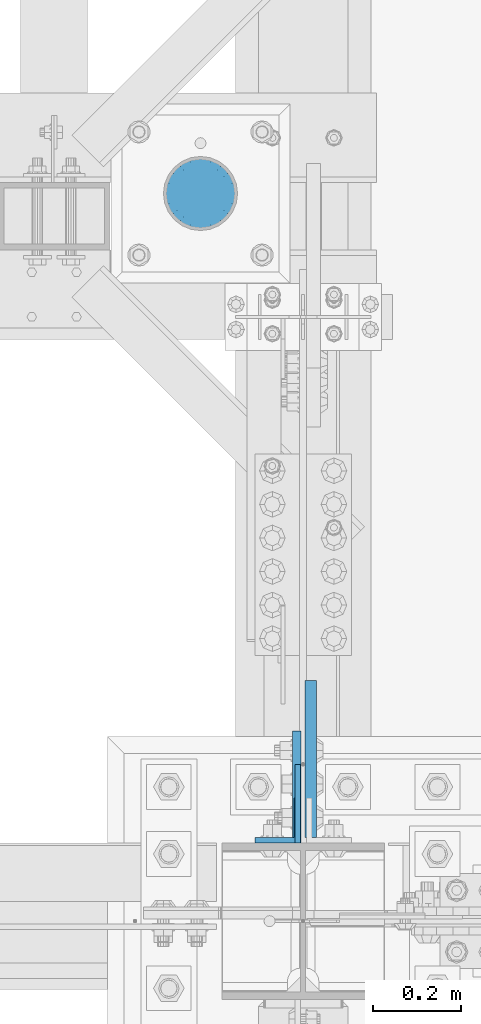
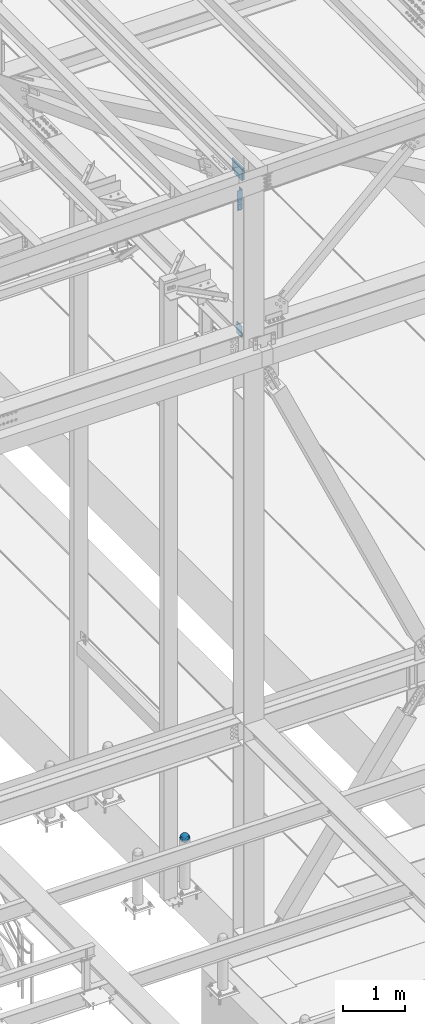
# One storey, part 1461 of 3843: 5 columns, 4 elements without a shape of their own.
"""IFC2X3 building model written with IfcOpenShell, lengths in millimetres."""

from ifc_helpers import new_model, si_unit, frame, origin_with_axes, place, context, subcontext, project, spatial, faceted_brep, material, type_object, element, aggregate, save


model = new_model("IFC2X3")

# Units and contexts
model_context = context("Model", 3, precision=1e-05, world=origin_with_axes())
body_context = subcontext(model_context, "Body", "Model", "MODEL_VIEW")
ifc_project = project(units=[si_unit("LENGTHUNIT", "METRE", prefix="MILLI"), si_unit("AREAUNIT", "SQUARE_METRE"), si_unit("VOLUMEUNIT", "CUBIC_METRE"), si_unit("MASSUNIT", "GRAM", prefix="KILO"), si_unit("TIMEUNIT", "SECOND"), si_unit("PLANEANGLEUNIT", "RADIAN"), si_unit("SOLIDANGLEUNIT", "STERADIAN"), si_unit("THERMODYNAMICTEMPERATUREUNIT", "DEGREE_CELSIUS"), si_unit("LUMINOUSINTENSITYUNIT", "LUMEN")], contexts=[model_context])

# Site, building, storey
site_placement = place(None, origin_with_axes())
site = spatial("IfcSite", under=ifc_project, at=site_placement, CompositionType="ELEMENT")
building_placement = place(site_placement, origin_with_axes())
building = spatial("IfcBuilding", under=site, at=building_placement, Name="Undefined", CompositionType="ELEMENT")
storey_placement = place(building_placement, origin_with_axes())
storey = spatial("IfcBuildingStorey", under=building, at=storey_placement, Name="Undefined", CompositionType="ELEMENT", Elevation=0.0)

# Assembly, column
assembly_1_placement = place(storey_placement, origin_with_axes())
assembly_1 = element("IfcElementAssembly", 1, at=assembly_1_placement, inside=storey, Name="CONC. FILL", AssemblyPlace="NOTDEFINED", PredefinedType="REINFORCEMENT_UNIT")
ifc_material_1 = material(Name="CONCRETE/1500")
column_type_1 = type_object("IfcColumnType", PredefinedType="NOTDEFINED")
column_1_placement = place(assembly_1_placement, frame((41829.4014282227, 27267.6153033043, 31411.8625), z_axis=(-1.0, 0.0, 0.0), x_axis=(0.0, 0.0, 1.0)))
column_1 = element("IfcColumn", 2, at=column_1_placement, type_object=column_type_1, material=ifc_material_1, Name="CONC. FILL", context=body_context, shape_type="Brep", body=[
    faceted_brep([(0.0, 0.0, 2.0), (0.0, -0.619999999995343, 1.89999999999964), (3.36549999999988, -7.1422259999963, 21.9814139999999), (3.36549999999988, 0.0, 23.1139999999996), (0.0, -1.17999999999302, 1.6200000000008), (3.36549999999988, -13.5910319999966, 18.6992260000006), (0.0, -1.61999999999534, 1.18000000000029), (3.36549999999988, -18.699225999997, 13.5910320000003), (0.0, -1.89999999999418, 0.6200000000008), (3.36549999999988, -21.9814139999944, 7.14222599999994), (0.0, -2.0, 0.0), (3.36549999999988, -23.1140000000014, 0.0), (0.0, -1.89999999999418, -0.6200000000008), (3.36549999999988, -21.9814139999944, -7.14222599999994), (0.0, -1.61999999999534, -1.18000000000029), (3.36549999999988, -18.699225999997, -13.5910320000003), (0.0, -1.17999999999302, -1.6200000000008), (3.36549999999988, -13.5910319999966, -18.6992260000006), (0.0, -0.619999999995343, -1.89999999999964), (3.36549999999988, -7.1422259999963, -21.9814139999999), (0.0, 0.0, -2.0), (3.36549999999988, 0.0, -23.1139999999996), (0.0, 0.619999999995343, -1.89999999999964), (3.36549999999988, 7.1422259999963, -21.9814139999999), (0.0, 1.17999999999302, -1.6200000000008), (3.36549999999988, 13.5910319999966, -18.6992260000006), (0.0, 1.61999999999534, -1.18000000000029), (3.36549999999988, 18.699225999997, -13.5910320000003), (0.0, 1.89999999999418, -0.6200000000008), (3.36549999999988, 21.9814139999944, -7.14222599999994), (0.0, 2.0, 0.0), (3.36549999999988, 23.1140000000014, 0.0), (0.0, 1.89999999999418, 0.6200000000008), (3.36549999999988, 21.9814139999944, 7.14222599999994), (0.0, 1.61999999999534, 1.18000000000029), (3.36549999999988, 18.699225999997, 13.5910320000003), (0.0, 1.17999999999302, 1.6200000000008), (3.36549999999988, 13.5910319999966, 18.6992260000006), (0.0, 0.619999999995343, 1.89999999999964), (3.36549999999988, 7.1422259999963, 21.9814139999999), (8.41374999999971, -11.1214661999984, 34.2282018000005), (8.41374999999971, 0.0, 35.9917999999998), (8.41374999999971, -21.1631784000056, 29.1173662000001), (8.41374999999971, -29.1173661999928, 21.1631784000001), (8.41374999999971, -34.2282017999969, 11.1214662000002), (8.41374999999971, -35.9918000000034, 0.0), (8.41374999999971, -34.2282017999969, -11.1214662000002), (8.41374999999971, -29.1173661999928, -21.1631784000001), (8.41374999999971, -21.1631784000056, -29.1173662000001), (8.41374999999971, -11.1214661999984, -34.2282018000005), (8.41374999999971, 0.0, -35.9917999999998), (8.41374999999971, 11.1214661999984, -34.2282018000005), (8.41374999999971, 21.1631784000056, -29.1173662000001), (8.41374999999971, 29.1173661999928, -21.1631784000001), (8.41374999999971, 34.2282017999969, -11.1214662000002), (8.41374999999971, 35.9918000000034, 0.0), (8.41374999999971, 34.2282017999969, 11.1214662000002), (8.41374999999971, 29.1173661999928, 21.1631784000001), (8.41374999999971, 21.1631784000056, 29.1173662000001), (8.41374999999971, 11.1214661999984, 34.2282018000005), (16.8274999999994, -15.3047700000025, 47.1030300000002), (16.8274999999994, 0.0, 49.5300000000007), (16.8274999999994, -29.1236400000053, 40.0697700000001), (16.8274999999994, -40.0697700000019, 29.1236399999998), (16.8274999999994, -47.1030299999984, 15.3047700000006), (16.8274999999994, -49.5299999999988, 0.0), (16.8274999999994, -47.1030299999984, -15.3047700000006), (16.8274999999994, -40.0697700000019, -29.1236399999998), (16.8274999999994, -29.1236400000053, -40.0697700000001), (16.8274999999994, -15.3047700000025, -47.1030300000002), (16.8274999999994, 0.0, -49.5300000000007), (16.8274999999994, 15.3047700000025, -47.1030300000002), (16.8274999999994, 29.1236400000053, -40.0697700000001), (16.8274999999994, 40.0697700000019, -29.1236399999998), (16.8274999999994, 47.1030299999984, -15.3047700000006), (16.8274999999994, 49.5299999999988, 0.0), (16.8274999999994, 47.1030299999984, 15.3047700000006), (16.8274999999994, 40.0697700000019, 29.1236399999998), (16.8274999999994, 29.1236400000053, 40.0697700000001), (16.8274999999994, 15.3047700000025, 47.1030300000002), (33.6549999999988, -20.4063599999936, 62.8040400000009), (33.6549999999988, 0.0, 66.0400000000009), (33.6549999999988, -38.831520000007, 53.4263599999995), (33.6549999999988, -53.4263599999977, 38.8315199999997), (33.6549999999988, -62.8040400000027, 20.4063600000009), (33.6549999999988, -66.0399999999936, 0.0), (33.6549999999988, -62.8040400000027, -20.4063600000009), (33.6549999999988, -53.4263599999977, -38.8315199999997), (33.6549999999988, -38.831520000007, -53.4263599999995), (33.6549999999988, -20.4063599999936, -62.8040400000009), (33.6549999999988, 0.0, -66.0400000000009), (33.6549999999988, 20.4063599999936, -62.8040400000009), (33.6549999999988, 38.831520000007, -53.4263599999995), (33.6549999999988, 53.4263599999977, -38.8315199999997), (33.6549999999988, 62.8040400000027, -20.4063600000009), (33.6549999999988, 66.0399999999936, 0.0), (33.6549999999988, 62.8040400000027, 20.4063600000009), (33.6549999999988, 53.4263599999977, 38.8315199999997), (33.6549999999988, 38.831520000007, 53.4263599999995), (33.6549999999988, 20.4063599999936, 62.8040400000009), (50.4824999999983, -23.3907901500061, 71.9891308499991), (50.4824999999983, 0.0, 75.6983500000006), (50.4824999999983, -44.5106298000028, 61.23996515), (50.4824999999983, -61.2399651500018, 44.5106297999992), (50.4824999999983, -71.9891308499937, 23.3907901500006), (50.4824999999983, -75.698350000006, 0.0), (50.4824999999983, -71.9891308499937, -23.3907901500006), (50.4824999999983, -61.2399651500018, -44.5106297999992), (50.4824999999983, -44.5106298000028, -61.23996515), (50.4824999999983, -23.3907901500061, -71.9891308499991), (50.4824999999983, 0.0, -75.6983500000006), (50.4824999999983, 23.3907901500061, -71.9891308499991), (50.4824999999983, 44.5106298000028, -61.23996515), (50.4824999999983, 61.2399651500018, -44.5106297999992), (50.4824999999983, 71.9891308499937, -23.3907901500006), (50.4824999999983, 75.698350000006, 0.0), (50.4824999999983, 71.9891308499937, 23.3907901500006), (50.4824999999983, 61.2399651500018, 44.5106297999992), (50.4824999999983, 44.5106298000028, 61.23996515), (50.4824999999983, 23.3907901500061, 71.9891308499991), (67.3099999999977, -24.9977910000016, 76.9349490000004), (67.3099999999977, 0.0, 80.8989999999994), (67.3099999999977, -47.5686120000028, 65.4472910000004), (67.3099999999977, -65.447291000004, 47.5686119999991), (67.3099999999977, -76.9349490000022, 24.9977909999998), (67.3099999999977, -80.8990000000049, 0.0), (67.3099999999977, -76.9349490000022, -24.9977909999998), (67.3099999999977, -65.447291000004, -47.5686119999991), (67.3099999999977, -47.5686120000028, -65.4472910000004), (67.3099999999977, -24.9977910000016, -76.9349490000004), (67.3099999999977, 0.0, -80.8989999999994), (67.3099999999977, 24.9977910000016, -76.9349490000004), (67.3099999999977, 47.5686120000028, -65.4472910000004), (67.3099999999977, 65.447291000004, -47.5686119999991), (67.3099999999977, 76.9349490000022, -24.9977909999998), (67.3099999999977, 80.8990000000049, 0.0), (67.3099999999977, 76.9349490000022, 24.9977909999998), (67.3099999999977, 65.447291000004, 47.5686119999991), (67.3099999999977, 47.5686120000028, 65.4472910000004), (67.3099999999977, 24.9977910000016, 76.9349490000004), (84.1374999999935, -25.5079499999993, 78.5050499999998), (84.1374999999935, 0.0, 82.5499999999993), (84.1374999999935, -48.5393999999942, 66.7829500000007), (84.1374999999935, -66.7829499999934, 48.5393999999997), (84.1374999999935, -78.505050000007, 25.5079499999993), (84.1374999999935, -82.5500000000029, 0.0), (84.1374999999935, -78.505050000007, -25.5079499999993), (84.1374999999935, -66.7829499999934, -48.5393999999997), (84.1374999999935, -48.5393999999942, -66.7829500000007), (84.1374999999935, -25.5079499999993, -78.5050499999998), (84.1374999999935, 0.0, -82.5499999999993), (84.1374999999935, 25.5079499999993, -78.5050499999998), (84.1374999999935, 48.5393999999942, -66.7829500000007), (84.1374999999935, 66.7829499999934, -48.5393999999997), (84.1374999999935, 78.505050000007, -25.5079499999993), (84.1374999999935, 82.5500000000029, 0.0), (84.1374999999935, 78.505050000007, 25.5079499999993), (84.1374999999935, 66.7829499999934, 48.5393999999997), (84.1374999999935, 48.5393999999942, 66.7829500000007), (84.1374999999935, 25.5079499999993, 78.5050499999998), (100.964999999993, -24.9977910000016, 76.9349490000004), (100.964999999993, 0.0, 80.8989999999994), (100.964999999993, -47.5686120000028, 65.4472910000004), (100.964999999993, -65.447291000004, 47.5686119999991), (100.964999999993, -76.9349490000022, 24.9977909999998), (100.964999999993, -80.8990000000049, 0.0), (100.964999999993, -76.9349490000022, -24.9977909999998), (100.964999999993, -65.447291000004, -47.5686119999991), (100.964999999993, -47.5686120000028, -65.4472910000004), (100.964999999993, -24.9977910000016, -76.9349490000004), (100.964999999993, 0.0, -80.8989999999994), (100.964999999993, 24.9977910000016, -76.9349490000004), (100.964999999993, 47.5686120000028, -65.4472910000004), (100.964999999993, 65.447291000004, -47.5686119999991), (100.964999999993, 76.9349490000022, -24.9977909999998), (100.964999999993, 80.8990000000049, 0.0), (100.964999999993, 76.9349490000022, 24.9977909999998), (100.964999999993, 65.447291000004, 47.5686119999991), (100.964999999993, 47.5686120000028, 65.4472910000004), (100.964999999993, 24.9977910000016, 76.9349490000004), (117.792499999992, -23.3907901500061, 71.9891308499991), (117.792499999992, 0.0, 75.6983500000006), (117.792499999992, -44.5106298000028, 61.23996515), (117.792499999992, -61.2399651500018, 44.5106297999992), (117.792499999992, -71.9891308499937, 23.3907901500006), (117.792499999992, -75.698350000006, 0.0), (117.792499999992, -71.9891308499937, -23.3907901500006), (117.792499999992, -61.2399651500018, -44.5106297999992), (117.792499999992, -44.5106298000028, -61.23996515), (117.792499999992, -23.3907901500061, -71.9891308499991), (117.792499999992, 0.0, -75.6983500000006), (117.792499999992, 23.3907901500061, -71.9891308499991), (117.792499999992, 44.5106298000028, -61.23996515), (117.792499999992, 61.2399651500018, -44.5106297999992), (117.792499999992, 71.9891308499937, -23.3907901500006), (117.792499999992, 75.698350000006, 0.0), (117.792499999992, 71.9891308499937, 23.3907901500006), (117.792499999992, 61.2399651500018, 44.5106297999992), (117.792499999992, 44.5106298000028, 61.23996515), (117.792499999992, 23.3907901500061, 71.9891308499991), (134.619999999992, -20.4063599999936, 62.8040400000009), (134.619999999992, 0.0, 66.0400000000009), (134.619999999992, -38.831520000007, 53.4263599999995), (134.619999999992, -53.4263599999977, 38.8315199999997), (134.619999999992, -62.8040400000027, 20.4063600000009), (134.619999999992, -66.0399999999936, 0.0), (134.619999999992, -62.8040400000027, -20.4063600000009), (134.619999999992, -53.4263599999977, -38.8315199999997), (134.619999999992, -38.831520000007, -53.4263599999995), (134.619999999992, -20.4063599999936, -62.8040400000009), (134.619999999992, 0.0, -66.0400000000009), (134.619999999992, 20.4063599999936, -62.8040400000009), (134.619999999992, 38.831520000007, -53.4263599999995), (134.619999999992, 53.4263599999977, -38.8315199999997), (134.619999999992, 62.8040400000027, -20.4063600000009), (134.619999999992, 66.0399999999936, 0.0), (134.619999999992, 62.8040400000027, 20.4063600000009), (134.619999999992, 53.4263599999977, 38.8315199999997), (134.619999999992, 38.831520000007, 53.4263599999995), (134.619999999992, 20.4063599999936, 62.8040400000009), (151.447499999991, -15.3047700000025, 47.1030300000002), (151.447499999991, 0.0, 49.5300000000007), (151.447499999991, -29.1236400000053, 40.0697700000001), (151.447499999991, -40.0697700000019, 29.1236399999998), (151.447499999991, -47.1030299999984, 15.3047700000006), (151.447499999991, -49.5299999999988, 0.0), (151.447499999991, -47.1030299999984, -15.3047700000006), (151.447499999991, -40.0697700000019, -29.1236399999998), (151.447499999991, -29.1236400000053, -40.0697700000001), (151.447499999991, -15.3047700000025, -47.1030300000002), (151.447499999991, 0.0, -49.5300000000007), (151.447499999991, 15.3047700000025, -47.1030300000002), (151.447499999991, 29.1236400000053, -40.0697700000001), (151.447499999991, 40.0697700000019, -29.1236399999998), (151.447499999991, 47.1030299999984, -15.3047700000006), (151.447499999991, 49.5299999999988, 0.0), (151.447499999991, 47.1030299999984, 15.3047700000006), (151.447499999991, 40.0697700000019, 29.1236399999998), (151.447499999991, 29.1236400000053, 40.0697700000001), (151.447499999991, 15.3047700000025, 47.1030300000002), (159.861249999991, -11.1214661999984, 34.2282018000005), (159.861249999991, 0.0, 35.9917999999998), (159.861249999991, -21.1631784000056, 29.1173662000001), (159.861249999991, -29.1173661999928, 21.1631784000001), (159.861249999991, -34.2282017999969, 11.1214662000002), (159.861249999991, -35.9918000000034, 0.0), (159.861249999991, -34.2282017999969, -11.1214662000002), (159.861249999991, -29.1173661999928, -21.1631784000001), (159.861249999991, -21.1631784000056, -29.1173662000001), (159.861249999991, -11.1214661999984, -34.2282018000005), (159.861249999991, 0.0, -35.9917999999998), (159.861249999991, 11.1214661999984, -34.2282018000005), (159.861249999991, 21.1631784000056, -29.1173662000001), (159.861249999991, 29.1173661999928, -21.1631784000001), (159.861249999991, 34.2282017999969, -11.1214662000002), (159.861249999991, 35.9918000000034, 0.0), (159.861249999991, 34.2282017999969, 11.1214662000002), (159.861249999991, 29.1173661999928, 21.1631784000001), (159.861249999991, 21.1631784000056, 29.1173662000001), (159.861249999991, 11.1214661999984, 34.2282018000005), (164.909499999991, -7.1422259999963, 21.9814139999999), (164.909499999991, 0.0, 23.1139999999996), (164.909499999991, -13.5910319999966, 18.6992260000006), (164.909499999991, -18.699225999997, 13.5910320000003), (164.909499999991, -21.9814139999944, 7.14222599999994), (164.909499999991, -23.1140000000014, 0.0), (164.909499999991, -21.9814139999944, -7.14222599999994), (164.909499999991, -18.699225999997, -13.5910320000003), (164.909499999991, -13.5910319999966, -18.6992260000006), (164.909499999991, -7.1422259999963, -21.9814139999999), (164.909499999991, 0.0, -23.1139999999996), (164.909499999991, 7.1422259999963, -21.9814139999999), (164.909499999991, 13.5910319999966, -18.6992260000006), (164.909499999991, 18.699225999997, -13.5910320000003), (164.909499999991, 21.9814139999944, -7.14222599999994), (164.909499999991, 23.1140000000014, 0.0), (164.909499999991, 21.9814139999944, 7.14222599999994), (164.909499999991, 18.699225999997, 13.5910320000003), (164.909499999991, 13.5910319999966, 18.6992260000006), (164.909499999991, 7.1422259999963, 21.9814139999999), (168.274999999991, -0.619999999995343, 1.89999999999964), (168.274999999991, 0.0, 2.0), (168.274999999991, -1.17999999999302, 1.6200000000008), (168.274999999991, -1.61999999999534, 1.18000000000029), (168.274999999991, -1.89999999999418, 0.6200000000008), (168.274999999991, -2.0, 0.0), (168.274999999991, -1.89999999999418, -0.6200000000008), (168.274999999991, -1.61999999999534, -1.18000000000029), (168.274999999991, -1.17999999999302, -1.6200000000008), (168.274999999991, -0.619999999995343, -1.89999999999964), (168.274999999991, 0.0, -2.0), (168.274999999991, 0.619999999995343, -1.89999999999964), (168.274999999991, 1.17999999999302, -1.6200000000008), (168.274999999991, 1.61999999999534, -1.18000000000029), (168.274999999991, 1.89999999999418, -0.6200000000008), (168.274999999991, 2.0, 0.0), (168.274999999991, 1.89999999999418, 0.6200000000008), (168.274999999991, 1.61999999999534, 1.18000000000029), (168.274999999991, 1.17999999999302, 1.6200000000008), (168.274999999991, 0.619999999995343, 1.89999999999964)], [[[0, 1, 2, 3]], [[1, 4, 5, 2]], [[4, 6, 7, 5]], [[6, 8, 9, 7]], [[8, 10, 11, 9]], [[10, 12, 13, 11]], [[12, 14, 15, 13]], [[14, 16, 17, 15]], [[16, 18, 19, 17]], [[18, 20, 21, 19]], [[20, 22, 23, 21]], [[22, 24, 25, 23]], [[24, 26, 27, 25]], [[26, 28, 29, 27]], [[28, 30, 31, 29]], [[30, 32, 33, 31]], [[32, 34, 35, 33]], [[34, 36, 37, 35]], [[36, 38, 39, 37]], [[38, 0, 3, 39]], [[38, 36, 34, 32, 30, 28, 26, 24, 22, 20, 18, 16, 14, 12, 10, 8, 6, 4, 1, 0]], [[3, 2, 40, 41]], [[2, 5, 42, 40]], [[5, 7, 43, 42]], [[7, 9, 44, 43]], [[9, 11, 45, 44]], [[11, 13, 46, 45]], [[13, 15, 47, 46]], [[15, 17, 48, 47]], [[17, 19, 49, 48]], [[19, 21, 50, 49]], [[21, 23, 51, 50]], [[23, 25, 52, 51]], [[25, 27, 53, 52]], [[27, 29, 54, 53]], [[29, 31, 55, 54]], [[31, 33, 56, 55]], [[33, 35, 57, 56]], [[35, 37, 58, 57]], [[37, 39, 59, 58]], [[39, 3, 41, 59]], [[41, 40, 60, 61]], [[40, 42, 62, 60]], [[42, 43, 63, 62]], [[43, 44, 64, 63]], [[44, 45, 65, 64]], [[45, 46, 66, 65]], [[46, 47, 67, 66]], [[47, 48, 68, 67]], [[48, 49, 69, 68]], [[49, 50, 70, 69]], [[50, 51, 71, 70]], [[51, 52, 72, 71]], [[52, 53, 73, 72]], [[53, 54, 74, 73]], [[54, 55, 75, 74]], [[55, 56, 76, 75]], [[56, 57, 77, 76]], [[57, 58, 78, 77]], [[58, 59, 79, 78]], [[59, 41, 61, 79]], [[61, 60, 80, 81]], [[60, 62, 82, 80]], [[62, 63, 83, 82]], [[63, 64, 84, 83]], [[64, 65, 85, 84]], [[65, 66, 86, 85]], [[66, 67, 87, 86]], [[67, 68, 88, 87]], [[68, 69, 89, 88]], [[69, 70, 90, 89]], [[70, 71, 91, 90]], [[71, 72, 92, 91]], [[72, 73, 93, 92]], [[73, 74, 94, 93]], [[74, 75, 95, 94]], [[75, 76, 96, 95]], [[76, 77, 97, 96]], [[77, 78, 98, 97]], [[78, 79, 99, 98]], [[79, 61, 81, 99]], [[81, 80, 100, 101]], [[80, 82, 102, 100]], [[82, 83, 103, 102]], [[83, 84, 104, 103]], [[84, 85, 105, 104]], [[85, 86, 106, 105]], [[86, 87, 107, 106]], [[87, 88, 108, 107]], [[88, 89, 109, 108]], [[89, 90, 110, 109]], [[90, 91, 111, 110]], [[91, 92, 112, 111]], [[92, 93, 113, 112]], [[93, 94, 114, 113]], [[94, 95, 115, 114]], [[95, 96, 116, 115]], [[96, 97, 117, 116]], [[97, 98, 118, 117]], [[98, 99, 119, 118]], [[99, 81, 101, 119]], [[101, 100, 120, 121]], [[100, 102, 122, 120]], [[102, 103, 123, 122]], [[103, 104, 124, 123]], [[104, 105, 125, 124]], [[105, 106, 126, 125]], [[106, 107, 127, 126]], [[107, 108, 128, 127]], [[108, 109, 129, 128]], [[109, 110, 130, 129]], [[110, 111, 131, 130]], [[111, 112, 132, 131]], [[112, 113, 133, 132]], [[113, 114, 134, 133]], [[114, 115, 135, 134]], [[115, 116, 136, 135]], [[116, 117, 137, 136]], [[117, 118, 138, 137]], [[118, 119, 139, 138]], [[119, 101, 121, 139]], [[121, 120, 140, 141]], [[120, 122, 142, 140]], [[122, 123, 143, 142]], [[123, 124, 144, 143]], [[124, 125, 145, 144]], [[125, 126, 146, 145]], [[126, 127, 147, 146]], [[127, 128, 148, 147]], [[128, 129, 149, 148]], [[129, 130, 150, 149]], [[130, 131, 151, 150]], [[131, 132, 152, 151]], [[132, 133, 153, 152]], [[133, 134, 154, 153]], [[134, 135, 155, 154]], [[135, 136, 156, 155]], [[136, 137, 157, 156]], [[137, 138, 158, 157]], [[138, 139, 159, 158]], [[139, 121, 141, 159]], [[141, 140, 160, 161]], [[140, 142, 162, 160]], [[142, 143, 163, 162]], [[143, 144, 164, 163]], [[144, 145, 165, 164]], [[145, 146, 166, 165]], [[146, 147, 167, 166]], [[147, 148, 168, 167]], [[148, 149, 169, 168]], [[149, 150, 170, 169]], [[150, 151, 171, 170]], [[151, 152, 172, 171]], [[152, 153, 173, 172]], [[153, 154, 174, 173]], [[154, 155, 175, 174]], [[155, 156, 176, 175]], [[156, 157, 177, 176]], [[157, 158, 178, 177]], [[158, 159, 179, 178]], [[159, 141, 161, 179]], [[161, 160, 180, 181]], [[160, 162, 182, 180]], [[162, 163, 183, 182]], [[163, 164, 184, 183]], [[164, 165, 185, 184]], [[165, 166, 186, 185]], [[166, 167, 187, 186]], [[167, 168, 188, 187]], [[168, 169, 189, 188]], [[169, 170, 190, 189]], [[170, 171, 191, 190]], [[171, 172, 192, 191]], [[172, 173, 193, 192]], [[173, 174, 194, 193]], [[174, 175, 195, 194]], [[175, 176, 196, 195]], [[176, 177, 197, 196]], [[177, 178, 198, 197]], [[178, 179, 199, 198]], [[179, 161, 181, 199]], [[181, 180, 200, 201]], [[180, 182, 202, 200]], [[182, 183, 203, 202]], [[183, 184, 204, 203]], [[184, 185, 205, 204]], [[185, 186, 206, 205]], [[186, 187, 207, 206]], [[187, 188, 208, 207]], [[188, 189, 209, 208]], [[189, 190, 210, 209]], [[190, 191, 211, 210]], [[191, 192, 212, 211]], [[192, 193, 213, 212]], [[193, 194, 214, 213]], [[194, 195, 215, 214]], [[195, 196, 216, 215]], [[196, 197, 217, 216]], [[197, 198, 218, 217]], [[198, 199, 219, 218]], [[199, 181, 201, 219]], [[201, 200, 220, 221]], [[200, 202, 222, 220]], [[202, 203, 223, 222]], [[203, 204, 224, 223]], [[204, 205, 225, 224]], [[205, 206, 226, 225]], [[206, 207, 227, 226]], [[207, 208, 228, 227]], [[208, 209, 229, 228]], [[209, 210, 230, 229]], [[210, 211, 231, 230]], [[211, 212, 232, 231]], [[212, 213, 233, 232]], [[213, 214, 234, 233]], [[214, 215, 235, 234]], [[215, 216, 236, 235]], [[216, 217, 237, 236]], [[217, 218, 238, 237]], [[218, 219, 239, 238]], [[219, 201, 221, 239]], [[221, 220, 240, 241]], [[220, 222, 242, 240]], [[222, 223, 243, 242]], [[223, 224, 244, 243]], [[224, 225, 245, 244]], [[225, 226, 246, 245]], [[226, 227, 247, 246]], [[227, 228, 248, 247]], [[228, 229, 249, 248]], [[229, 230, 250, 249]], [[230, 231, 251, 250]], [[231, 232, 252, 251]], [[232, 233, 253, 252]], [[233, 234, 254, 253]], [[234, 235, 255, 254]], [[235, 236, 256, 255]], [[236, 237, 257, 256]], [[237, 238, 258, 257]], [[238, 239, 259, 258]], [[239, 221, 241, 259]], [[241, 240, 260, 261]], [[240, 242, 262, 260]], [[242, 243, 263, 262]], [[243, 244, 264, 263]], [[244, 245, 265, 264]], [[245, 246, 266, 265]], [[246, 247, 267, 266]], [[247, 248, 268, 267]], [[248, 249, 269, 268]], [[249, 250, 270, 269]], [[250, 251, 271, 270]], [[251, 252, 272, 271]], [[252, 253, 273, 272]], [[253, 254, 274, 273]], [[254, 255, 275, 274]], [[255, 256, 276, 275]], [[256, 257, 277, 276]], [[257, 258, 278, 277]], [[258, 259, 279, 278]], [[259, 241, 261, 279]], [[261, 260, 280, 281]], [[260, 262, 282, 280]], [[262, 263, 283, 282]], [[263, 264, 284, 283]], [[264, 265, 285, 284]], [[265, 266, 286, 285]], [[266, 267, 287, 286]], [[267, 268, 288, 287]], [[268, 269, 289, 288]], [[269, 270, 290, 289]], [[270, 271, 291, 290]], [[271, 272, 292, 291]], [[272, 273, 293, 292]], [[273, 274, 294, 293]], [[274, 275, 295, 294]], [[275, 276, 296, 295]], [[276, 277, 297, 296]], [[277, 278, 298, 297]], [[278, 279, 299, 298]], [[279, 261, 281, 299]], [[282, 283, 284, 285, 286, 287, 288, 289, 290, 291, 292, 293, 294, 295, 296, 297, 298, 299, 281, 280]]]),
])
aggregate(assembly_1, [column_1])

assembly_2_placement = place(storey_placement, origin_with_axes())
assembly_2 = element("IfcElementAssembly", 3, at=assembly_2_placement, inside=storey, Name="COLUMN", AssemblyPlace="NOTDEFINED", PredefinedType="RIGID_FRAME")
ifc_material_2 = material(Name="STEEL/A572-50")
column_type_2 = type_object("IfcColumnType", PredefinedType="NOTDEFINED")
column_2_placement = place(assembly_2_placement, frame((42049.7, 25882.5870000002, 42130.7381223477), z_axis=(0.0, -1.0, 0.0), x_axis=(0.0, 0.0, 1.0)))
column_2 = element("IfcColumn", 4, at=column_2_placement, type_object=column_type_2, material=ifc_material_2, Name="PLATE", context=body_context, shape_type="Brep", body=[
    faceted_brep([(0.0, 6.34999999999854, -88.8870000000024), (0.0, 6.34999999999854, 88.8870000000024), (228.599999999991, 6.34999999999854, 88.8870000000024), (228.599999999991, 6.34999999999854, -88.8870000000024), (0.0, -6.34999999999854, 88.8870000000024), (228.599999999991, -6.34999999999854, 88.8870000000024), (0.0, -6.34999999999854, -88.8870000000024), (228.599999999991, -6.34999999999854, -88.8870000000024)], [[[0, 1, 2, 3]], [[1, 4, 5, 2]], [[4, 6, 7, 5]], [[6, 0, 3, 7]], [[5, 7, 3, 2]], [[6, 4, 1, 0]]]),
])

assembly_3_placement = place(storey_placement, origin_with_axes())
assembly_3 = element("IfcElementAssembly", 5, at=assembly_3_placement, inside=storey, Name="PLATE", AssemblyPlace="NOTDEFINED", PredefinedType="RIGID_FRAME")
column_type_3 = type_object("IfcColumnType", Name="L4X4X1/2", PredefinedType="NOTDEFINED")
column_3_placement = place(assembly_3_placement, frame((42003.6625000002, 25844.5000000038, 44671.8633527715), z_axis=(0.0, 1.0, 0.0), x_axis=(0.0, 0.0, 1.0)))
column_3 = element("IfcColumn", 6, at=column_3_placement, type_object=column_type_3, material=ifc_material_2, Name="ANGLE", ObjectType="L4X4X1/2", context=body_context, shape_type="Brep", body=[
    faceted_brep([(0.0, 50.8000000000029, -50.8000000000029), (0.0, 50.8000000000029, 50.8000000000029), (381.0, 50.8000000000029, 50.8000000000029), (381.0, 50.8000000000029, -50.8000000000029), (0.0, 38.0999999999985, 50.8000000000029), (381.0, 38.0999999999985, 50.8000000000029), (0.0, 38.0999999999985, -38.0999999999985), (381.0, 38.0999999999985, -38.1000000000058), (0.0, -50.8000000000029, -38.1000000000058), (381.0, -50.8000000000029, -38.1000000000058), (0.0, -50.8000000000029, -50.8000000000029), (381.0, -50.8000000000029, -50.8000000000029)], [[[0, 1, 2, 3]], [[1, 4, 5, 2]], [[4, 6, 7, 5]], [[6, 8, 9, 7]], [[8, 10, 11, 9]], [[10, 0, 3, 11]], [[5, 7, 9, 11, 3, 2]], [[10, 8, 6, 4, 1, 0]]]),
])
aggregate(assembly_3, [column_3])

# Column
column_type_4 = type_object("IfcColumnType", PredefinedType="NOTDEFINED")
column_4_placement = place(assembly_2_placement, frame((42048.1125, 25920.7, 45225.9008521075), z_axis=(0.0, -1.0, 0.0), x_axis=(0.0, 0.0, 1.0)))
column_4 = element("IfcColumn", 7, at=column_4_placement, type_object=column_type_4, material=ifc_material_2, Name="PLATE", context=body_context, shape_type="Brep", body=[
    faceted_brep([(0.0, 9.52499999999418, -127.0), (0.0, 9.52499999999418, 127.0), (228.599999999999, 9.52499999999418, 127.0), (228.599999999999, 9.52499999999418, -127.0), (0.0, -9.52499999999418, 127.0), (228.599999999999, -9.52499999999418, 127.0), (0.0, -9.52499999999418, -127.0), (228.599999999999, -9.52499999999418, -127.0)], [[[0, 1, 2, 3]], [[1, 4, 5, 2]], [[4, 6, 7, 5]], [[6, 0, 3, 7]], [[5, 7, 3, 2]], [[6, 4, 1, 0]]]),
])

aggregate(assembly_2, [column_2, column_4])

# Assembly, column
assembly_4_placement = place(storey_placement, origin_with_axes())
assembly_4 = element("IfcElementAssembly", 8, at=assembly_4_placement, inside=storey, Name="BEAM", AssemblyPlace="NOTDEFINED", PredefinedType="RIGID_FRAME")
column_type_5 = type_object("IfcColumnType", PredefinedType="NOTDEFINED")
column_5_placement = place(assembly_4_placement, frame((42079.8624999189, 25984.2, 45225.9008521075), z_axis=(0.0, -1.0, 0.0), x_axis=(0.0, 0.0, 1.0)))
column_5 = element("IfcColumn", 9, at=column_5_placement, type_object=column_type_5, material=ifc_material_2, Name="PLATE", context=body_context, shape_type="Brep", body=[
    faceted_brep([(-1.45519152283669e-11, 12.7000000000025, -177.800000000003), (-1.45519152283669e-11, 12.7000000000025, 177.800000000003), (228.600000000013, 12.6999999999971, 177.799999999999), (228.600000000013, 12.6999999999971, -177.799999999999), (4.36557456851006e-11, -12.7000000000171, 177.800000000003), (228.600000000013, -12.6999999999971, 177.799999999999), (4.36557456851006e-11, -12.7000000000171, -177.800000000003), (228.600000000013, -12.6999999999971, -177.799999999999)], [[[0, 1, 2, 3]], [[1, 4, 5, 2]], [[4, 6, 7, 5]], [[6, 0, 3, 7]], [[5, 7, 3, 2]], [[6, 4, 1, 0]]]),
])
aggregate(assembly_4, [column_5])

save(model, "model.ifc")
